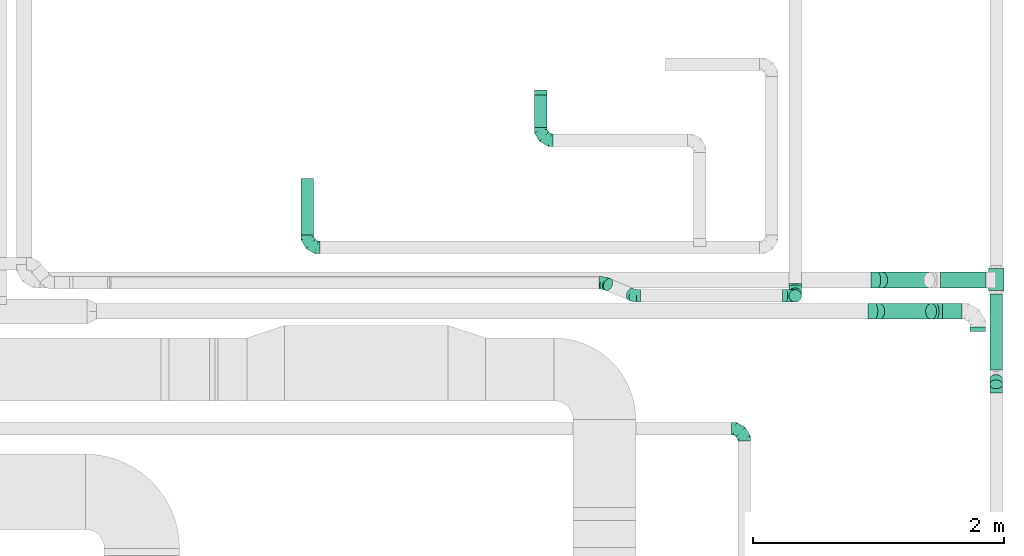
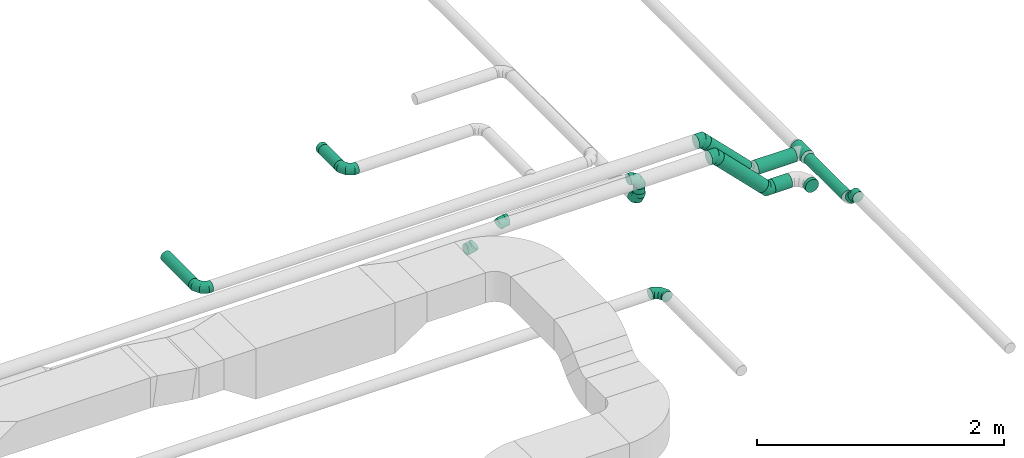
# One storey, part 50 of 60: 12 flow fittings, 11 flow segments.
"""IFC2X3 building model written with IfcOpenShell, lengths in millimetres."""

from ifc_helpers import new_model, entity, si_unit, converted_unit, derived_unit, direction, frame, origin, origin_2d_with_axis, place, context, subcontext, project, spatial, circle, extrude, faceted_brep, source, transform, mapped, material, type_object, type_shapes, element, save


model = new_model("IFC2X3")

# Units and contexts
model_context = context("Model", 3, precision=0.01, world=origin(), true_north=direction((6.12303176911189e-17, 1.0)))
body_context = subcontext(model_context, "Body", "Model", "MODEL_VIEW")
ifc_project = project(units=[si_unit("LENGTHUNIT", "METRE", prefix="MILLI"), si_unit("AREAUNIT", "SQUARE_METRE"), si_unit("VOLUMEUNIT", "CUBIC_METRE"), converted_unit("PLANEANGLEUNIT", "DEGREE", entity("IfcRatioMeasure", 0.0174532925199433), si_unit("PLANEANGLEUNIT", "RADIAN"), dimensions=[0, 0, 0, 0, 0, 0, 0]), si_unit("MASSUNIT", "GRAM", prefix="KILO"), derived_unit("MASSDENSITYUNIT", [(si_unit("MASSUNIT", "GRAM", prefix="KILO"), 1), (si_unit("LENGTHUNIT", "METRE"), -3)]), derived_unit("MOMENTOFINERTIAUNIT", [(si_unit("LENGTHUNIT", "METRE"), 4)]), si_unit("TIMEUNIT", "SECOND"), si_unit("FREQUENCYUNIT", "HERTZ"), si_unit("THERMODYNAMICTEMPERATUREUNIT", "DEGREE_CELSIUS"), derived_unit("THERMALTRANSMITTANCEUNIT", [(si_unit("MASSUNIT", "GRAM", prefix="KILO"), 1), (si_unit("THERMODYNAMICTEMPERATUREUNIT", "KELVIN"), -1), (si_unit("TIMEUNIT", "SECOND"), -3)]), derived_unit("VOLUMETRICFLOWRATEUNIT", [(si_unit("LENGTHUNIT", "METRE"), 3), (si_unit("TIMEUNIT", "SECOND"), -1)]), derived_unit("MASSFLOWRATEUNIT", [(si_unit("MASSUNIT", "GRAM", prefix="KILO"), 1), (si_unit("TIMEUNIT", "SECOND"), -1)]), derived_unit("ROTATIONALFREQUENCYUNIT", [(si_unit("TIMEUNIT", "SECOND"), -1)]), si_unit("ELECTRICCURRENTUNIT", "AMPERE"), si_unit("ELECTRICVOLTAGEUNIT", "VOLT"), si_unit("POWERUNIT", "WATT"), si_unit("FORCEUNIT", "NEWTON", prefix="KILO"), si_unit("ILLUMINANCEUNIT", "LUX"), si_unit("LUMINOUSFLUXUNIT", "LUMEN"), si_unit("LUMINOUSINTENSITYUNIT", "CANDELA"), derived_unit("USERDEFINED", [(si_unit("MASSUNIT", "GRAM", prefix="KILO"), -1), (si_unit("LENGTHUNIT", "METRE"), -2), (si_unit("TIMEUNIT", "SECOND"), 3), (si_unit("LUMINOUSFLUXUNIT", "LUMEN"), 1)]), derived_unit("LINEARVELOCITYUNIT", [(si_unit("LENGTHUNIT", "METRE"), 1), (si_unit("TIMEUNIT", "SECOND"), -1)]), si_unit("PRESSUREUNIT", "PASCAL"), derived_unit("USERDEFINED", [(si_unit("LENGTHUNIT", "METRE"), -2), (si_unit("MASSUNIT", "GRAM", prefix="KILO"), 1), (si_unit("TIMEUNIT", "SECOND"), -2)]), derived_unit("LINEARFORCEUNIT", [(si_unit("MASSUNIT", "GRAM", prefix="KILO"), 1), (si_unit("LENGTHUNIT", "METRE"), 1), (si_unit("TIMEUNIT", "SECOND"), -2), (si_unit("LENGTHUNIT", "METRE"), -1)]), derived_unit("PLANARFORCEUNIT", [(si_unit("MASSUNIT", "GRAM", prefix="KILO"), 1), (si_unit("LENGTHUNIT", "METRE"), 1), (si_unit("TIMEUNIT", "SECOND"), -2), (si_unit("LENGTHUNIT", "METRE"), -2)])], contexts=[model_context])

# Site, building, storey
site_placement = place(None, origin())
site = spatial("IfcSite", under=ifc_project, at=site_placement, CompositionType="ELEMENT")
building_placement = place(site_placement, origin())
building = spatial("IfcBuilding", under=site, at=building_placement, CompositionType="ELEMENT")
storey_placement = place(building_placement, frame((0.0, 0.0, 19800.0)))
storey = spatial("IfcBuildingStorey", under=building, at=storey_placement, CompositionType="ELEMENT", Elevation=19800.0)

# Flow segments
duct_segment_type = type_object("IfcDuctSegmentType", PredefinedType="NOTDEFINED")
flow_segment_1_placement = place(storey_placement, frame((71263.72, 9761.89, 3053.33)))
element("IfcFlowSegment", 1, at=flow_segment_1_placement, inside=storey, type_object=duct_segment_type, context=body_context, shape_type="SweptSolid", body=[
    extrude(circle(Radius=62.5, at=origin_2d_with_axis()), frame((460.07, 64.1, 45.79), z_axis=(-0.707106781186541, 0.0, 0.707106781186554), x_axis=(0.0, -1.0, 0.0)), (0.0, 0.0, 1.0), 585.875721063605),
])
flow_segment_2_placement = place(storey_placement, frame((71812.17, 9761.89, 2998.41)))
element("IfcFlowSegment", 2, at=flow_segment_2_placement, inside=storey, type_object=duct_segment_type, context=body_context, shape_type="SweptSolid", body=[
    extrude(circle(Radius=62.5, at=origin_2d_with_axis()), frame((0.01, 64.1, 64.1), z_axis=(0.999999995760712, 9.20791868074516e-05, 0.0), x_axis=(9.20791868074516e-05, -0.999999995760712, 0.0)), (0.0, 0.0, 1.0), 158.198285652603),
])
flow_segment_3_placement = place(storey_placement, frame((72031.28, 9666.3, 2998.4)))
element("IfcFlowSegment", 3, at=flow_segment_3_placement, inside=storey, type_object=duct_segment_type, context=body_context, shape_type="SweptSolid", body=[
    extrude(circle(Radius=62.5, at=origin_2d_with_axis()), frame((64.1, 0.01, 64.1), z_axis=(0.0, 0.999999993693271, 0.00011230965719456), x_axis=(-1.0, 0.0, 0.0)), (0.0, 0.0, 1.0), 34.6940980596113),
])
flow_segment_4_placement = place(storey_placement, frame((71286.91, 10011.33, 3090.85)))
element("IfcFlowSegment", 4, at=flow_segment_4_placement, inside=storey, type_object=duct_segment_type, context=body_context, shape_type="SweptSolid", body=[
    extrude(circle(Radius=62.5, at=origin_2d_with_axis()), frame((45.79, 64.1, 422.54), z_axis=(0.707106781186548, 0.0, -0.707106781186548), x_axis=(0.0, -1.0, 0.0)), (0.0, 0.0, 1.0), 532.806999099958),
])
flow_segment_5_placement = place(storey_placement, frame((71797.83, 10011.33, 3035.93)))
element("IfcFlowSegment", 5, at=flow_segment_5_placement, inside=storey, type_object=duct_segment_type, context=body_context, shape_type="SweptSolid", body=[
    extrude(circle(Radius=62.5, at=origin_2d_with_axis()), frame((0.01, 64.1, 64.1), z_axis=(0.999999996738574, 8.07641773404161e-05, 0.0), x_axis=(8.07641773404161e-05, -0.999999996738574, 0.0)), (0.0, 0.0, 1.0), 360.72352810149),
])
flow_segment_6_placement = place(storey_placement, frame((72176.96, 9990.72, 3035.81)))
element("IfcFlowSegment", 6, at=flow_segment_6_placement, inside=storey, type_object=duct_segment_type, context=body_context, shape_type="SweptSolid", body=[
    extrude(circle(Radius=62.5, at=origin_2d_with_axis()), frame((64.1, 175.01, 64.1), z_axis=(0.0, -0.999999990158603, 0.000140295384194005), x_axis=(1.0, 0.0, 0.0)), (0.0, 0.0, 1.0), 175.000000003778),
])
flow_segment_7_placement = place(storey_placement, frame((66705.01, 10434.99, 3448.4)))
element("IfcFlowSegment", 7, at=flow_segment_7_placement, inside=storey, type_object=duct_segment_type, context=body_context, shape_type="SweptSolid", body=[
    extrude(circle(Radius=50.0, at=origin_2d_with_axis()), frame((51.6, 0.0, 51.6), z_axis=(0.0, 1.0, 0.0), x_axis=(1.0, 0.0, 0.0)), (0.0, 0.0, 1.0), 450.000000000006),
])
flow_segment_8_placement = place(storey_placement, frame((68562.03, 11289.99, 3448.4)))
element("IfcFlowSegment", 8, at=flow_segment_8_placement, inside=storey, type_object=duct_segment_type, context=body_context, shape_type="SweptSolid", body=[
    extrude(circle(Radius=50.0, at=origin_2d_with_axis()), frame((51.6, 0.0, 51.6), z_axis=(0.0, 1.0, 0.0), x_axis=(1.0, 0.0, 0.0)), (0.0, 0.0, 1.0), 257.585253206116),
])
flow_segment_9_placement = place(storey_placement, frame((72189.46, 9208.07, 3092.34)))
element("IfcFlowSegment", 9, at=flow_segment_9_placement, inside=storey, type_object=duct_segment_type, context=body_context, shape_type="SweptSolid", body=[
    extrude(circle(Radius=50.0, at=origin_2d_with_axis()), frame((51.6, 36.95, 78.37), z_axis=(0.0, 0.707106781186548, -0.707106781186548), x_axis=(1.0, 0.0, 0.0)), (0.0, 0.0, 1.0), 58.5711812334434),
])
flow_segment_10_placement = place(storey_placement, frame((72189.46, 9357.14, 3048.31)))
element("IfcFlowSegment", 10, at=flow_segment_10_placement, inside=storey, type_object=duct_segment_type, context=body_context, shape_type="SweptSolid", body=[
    extrude(circle(Radius=50.0, at=origin_2d_with_axis()), frame((51.6, 0.01, 51.69), z_axis=(0.0, 0.999999986658688, -0.00016334816538309), x_axis=(1.0, 0.0, 0.0)), (0.0, 0.0, 1.0), 608.583325078976),
])
flow_segment_11_placement = place(storey_placement, frame((70589.2, 9897.61, 3350.0)))
element("IfcFlowSegment", 11, at=flow_segment_11_placement, inside=storey, type_object=duct_segment_type, context=body_context, shape_type="SweptSolid", body=[
    extrude(circle(Radius=50.0, at=origin_2d_with_axis()), frame((51.6, 51.6, 0.0), z_axis=(0.0, 0.0, 1.0), x_axis=(0.0, 1.0, 0.0)), (0.0, 0.0, 1.0), 50.0000000000233),
])

# Flow fittings
ifc_material = material()
duct_fitting_type_1 = type_object("IfcDuctFittingType", PredefinedType="NOTDEFINED", material=ifc_material)
shared_shape_1 = source(origin(), body_context, "Body", "Brep", [
    faceted_brep([(-100.0, 0.0, -50.0), (-100.0, -12.94, -48.3), (-100.0, -25.0, -43.3), (-100.0, -35.36, -35.36), (-100.0, -43.3, -25.0), (-100.0, -48.3, -12.94), (-100.0, -50.0, 0.0), (-100.0, -48.3, 12.94), (-100.0, -43.3, 25.0), (-100.0, -35.36, 35.36), (-100.0, -25.0, 43.3), (-100.0, -12.94, 48.3), (-100.0, 0.0, 50.0), (-100.0, 12.94, 48.3), (-100.0, 25.0, 43.3), (-100.0, 35.36, 35.36), (-100.0, 43.3, 25.0), (-100.0, 48.3, 12.94), (-100.0, 50.0, 0.0), (-100.0, 48.3, -12.94), (-100.0, 43.3, -25.0), (-100.0, 35.36, -35.36), (-100.0, 25.0, -43.3), (-100.0, 12.94, -48.3), (-76.67, 12.94, 48.3), (-79.9, 25.0, 43.3), (-73.21, 0.0, 50.0), (-82.68, 35.36, 35.36), (-86.15, 48.3, 12.94), (-86.6, 50.0, 0.0), (-84.81, 43.3, 25.0), (-84.81, 43.3, -25.0), (-82.68, 35.36, -35.36), (-86.15, 48.3, -12.94), (-76.67, 12.94, -48.3), (-73.21, 0.0, -50.0), (-79.9, 25.0, -43.3), (-69.74, -12.94, -48.3), (-66.51, -25.0, -43.3), (-63.73, -35.36, -35.36), (-61.6, -43.3, -25.0), (-60.26, -48.3, -12.94), (-59.81, -50.0, 0.0), (-60.26, -48.3, 12.94), (-61.6, -43.3, 25.0), (-63.73, -35.36, 35.36), (-66.51, -25.0, 43.3), (-69.74, -12.94, 48.3), (-36.27, 36.27, 48.3), (-45.1, 45.1, 43.3), (-26.79, 26.79, 50.0), (-52.68, 52.68, 35.36), (-58.49, 58.49, 25.0), (-62.15, 62.15, 12.94), (-63.4, 63.4, 0.0), (-62.15, 62.15, -12.94), (-58.49, 58.49, -25.0), (-52.68, 52.68, -35.36), (-36.27, 36.27, -48.3), (-26.79, 26.79, -50.0), (-45.1, 45.1, -43.3), (-17.32, 17.32, -48.3), (-8.49, 8.49, -43.3), (-0.91, 0.91, -35.36), (4.9, -4.9, -25.0), (8.56, -8.56, -12.94), (9.81, -9.81, 0.0), (8.56, -8.56, 12.94), (4.9, -4.9, 25.0), (-0.91, 0.91, 35.36), (-8.49, 8.49, 43.3), (-17.32, 17.32, 48.3), (-12.94, 76.67, 48.3), (-25.0, 79.9, 43.3), (0.0, 73.21, 50.0), (-35.36, 82.68, 35.36), (-43.3, 84.81, 25.0), (-48.3, 86.15, 12.94), (-50.0, 86.6, 0.0), (-48.3, 86.15, -12.94), (-43.3, 84.81, -25.0), (-35.36, 82.68, -35.36), (-12.94, 76.67, -48.3), (0.0, 73.21, -50.0), (-25.0, 79.9, -43.3), (12.94, 69.74, -48.3), (25.0, 66.51, -43.3), (35.36, 63.73, -35.36), (43.3, 61.6, -25.0), (48.3, 60.26, -12.94), (50.0, 59.81, 0.0), (48.3, 60.26, 12.94), (43.3, 61.6, 25.0), (35.36, 63.73, 35.36), (25.0, 66.51, 43.3), (12.94, 69.74, 48.3), (-12.94, 100.0, -48.3), (-25.0, 100.0, -43.3), (-35.36, 100.0, -35.36), (-43.3, 100.0, -25.0), (-48.3, 100.0, -12.94), (-50.0, 100.0, 0.0), (-48.3, 100.0, 12.94), (-43.3, 100.0, 25.0), (-35.36, 100.0, 35.36), (-25.0, 100.0, 43.3), (-12.94, 100.0, 48.3), (0.0, 100.0, 50.0), (12.94, 100.0, 48.3), (25.0, 100.0, 43.3), (35.36, 100.0, 35.36), (43.3, 100.0, 25.0), (48.3, 100.0, 12.94), (50.0, 100.0, 0.0), (48.3, 100.0, -12.94), (43.3, 100.0, -25.0), (35.36, 100.0, -35.36), (25.0, 100.0, -43.3), (12.94, 100.0, -48.3), (0.0, 100.0, -50.0)], [[[0, 1, 2, 3, 4, 5, 6, 7, 8, 9, 10, 11, 12, 13, 14, 15, 16, 17, 18, 19, 20, 21, 22, 23]], [[24, 25, 14, 13]], [[26, 24, 13, 12]], [[14, 25, 27, 15]], [[28, 29, 18, 17]], [[30, 28, 17, 16]], [[15, 27, 30, 16]], [[20, 31, 32, 21]], [[33, 31, 20, 19]], [[18, 29, 33, 19]], [[34, 35, 0, 23]], [[36, 34, 23, 22]], [[32, 36, 22, 21]], [[2, 1, 37, 38]], [[3, 2, 38, 39]], [[0, 35, 37, 1]], [[5, 4, 40, 41]], [[6, 5, 41, 42]], [[3, 39, 40, 4]], [[6, 42, 43, 7]], [[7, 43, 44, 8]], [[8, 44, 45, 9]], [[10, 46, 47, 11]], [[11, 47, 26, 12]], [[10, 9, 45, 46]], [[48, 49, 25, 24]], [[50, 48, 24, 26]], [[27, 25, 49, 51]], [[52, 53, 28, 30]], [[51, 52, 30, 27]], [[29, 28, 53, 54]], [[55, 56, 31, 33]], [[54, 55, 33, 29]], [[57, 32, 31, 56]], [[58, 59, 35, 34]], [[60, 58, 34, 36]], [[57, 60, 36, 32]], [[37, 35, 59, 61]], [[38, 37, 61, 62]], [[39, 38, 62, 63]], [[41, 40, 64, 65]], [[42, 41, 65, 66]], [[63, 64, 40, 39]], [[43, 42, 66, 67]], [[44, 43, 67, 68]], [[68, 69, 45, 44]], [[46, 45, 69, 70]], [[47, 46, 70, 71]], [[26, 47, 71, 50]], [[72, 73, 49, 48]], [[74, 72, 48, 50]], [[51, 49, 73, 75]], [[76, 77, 53, 52]], [[75, 76, 52, 51]], [[54, 53, 77, 78]], [[79, 80, 56, 55]], [[78, 79, 55, 54]], [[81, 57, 56, 80]], [[82, 83, 59, 58]], [[84, 82, 58, 60]], [[81, 84, 60, 57]], [[61, 59, 83, 85]], [[62, 61, 85, 86]], [[63, 62, 86, 87]], [[65, 64, 88, 89]], [[66, 65, 89, 90]], [[87, 88, 64, 63]], [[67, 66, 90, 91]], [[68, 67, 91, 92]], [[92, 93, 69, 68]], [[70, 69, 93, 94]], [[71, 70, 94, 95]], [[50, 71, 95, 74]], [[96, 97, 98, 99, 100, 101, 102, 103, 104, 105, 106, 107, 108, 109, 110, 111, 112, 113, 114, 115, 116, 117, 118, 119]], [[72, 74, 107, 106]], [[73, 72, 106, 105]], [[75, 73, 105, 104]], [[77, 76, 103, 102]], [[78, 77, 102, 101]], [[75, 104, 103, 76]], [[78, 101, 100, 79]], [[79, 100, 99, 80]], [[80, 99, 98, 81]], [[96, 119, 83, 82]], [[97, 96, 82, 84]], [[84, 81, 98, 97]], [[83, 119, 118, 85]], [[85, 118, 117, 86]], [[86, 117, 116, 87]], [[88, 115, 114, 89]], [[89, 114, 113, 90]], [[87, 116, 115, 88]], [[91, 90, 113, 112]], [[92, 91, 112, 111]], [[93, 92, 111, 110]], [[95, 94, 109, 108]], [[74, 95, 108, 107]], [[110, 109, 94, 93]]]),
])
type_shapes(duct_fitting_type_1, [shared_shape_1])
for number, where, z_axis, x_axis in (
    (12, (70234.19, 8891.89, 3150.0), (0.0, 0.0, 1.0), (0.0, 1.0, 0.0)),
    (13, (66756.61, 10334.99, 3500.0), (0.0, 0.0, 1.0), (0.0, -1.0, 0.0)),
    (14, (68613.63, 11189.99, 3500.0), (0.0, 0.0, 1.0), (0.0, -1.0, 0.0)),
    (15, (70640.8, 9949.2, 3250.0), (-1.0, 0.0, 0.0), (0.0, -1.0, 0.0)),
    (16, (70640.8, 9949.2, 3500.0), (0.0, -1.0, 0.0), (0.0, 0.0, 1.0)),
):
    element("IfcFlowFitting", number, at=place(storey_placement, frame(where, z_axis=z_axis, x_axis=x_axis)), inside=storey, type_object=duct_fitting_type_1, material=ifc_material, context=body_context, shape_type="MappedRepresentation", body=[
        mapped(shared_shape_1, transform((0.0, 0.0, 0.0), scale=1.0)),
    ])
duct_fitting_type_2 = type_object("IfcDuctFittingType", PredefinedType="NOTDEFINED", material=ifc_material)
shared_shape_2 = source(origin(), body_context, "Body", "Brep", [
    faceted_brep([(-51.78, 0.0, -62.5), (-51.78, -16.18, -60.37), (-51.78, -31.25, -54.13), (-51.78, -44.19, -44.19), (-51.78, -54.13, -31.25), (-51.78, -60.37, -16.18), (-51.78, -62.5, 0.0), (-51.78, -60.37, 16.18), (-51.78, -54.13, 31.25), (-51.78, -44.19, 44.19), (-51.78, -31.25, 54.13), (-51.78, -16.18, 60.37), (-51.78, 0.0, 62.5), (-51.78, 16.18, 60.37), (-51.78, 31.25, 54.13), (-51.78, 44.19, 44.19), (-51.78, 54.13, 31.25), (-51.78, 60.37, 16.18), (-51.78, 62.5, 0.0), (-51.78, 60.37, -16.18), (-51.78, 54.13, -31.25), (-51.78, 44.19, -44.19), (-51.78, 31.25, -54.13), (-51.78, 16.18, -60.37), (-6.7, 16.18, 60.37), (-12.94, 31.25, 54.13), (0.0, 0.0, 62.5), (-18.31, 44.19, 44.19), (-22.42, 54.13, 31.25), (-25.01, 60.37, 16.18), (-25.89, 62.5, 0.0), (-25.01, 60.37, -16.18), (-22.42, 54.13, -31.25), (-18.31, 44.19, -44.19), (-6.7, 16.18, -60.37), (0.0, 0.0, -62.5), (-12.94, 31.25, -54.13), (6.7, -16.18, -60.37), (12.94, -31.25, -54.13), (18.31, -44.19, -44.19), (22.42, -54.13, -31.25), (25.01, -60.37, -16.18), (25.89, -62.5, 0.0), (25.01, -60.37, 16.18), (22.42, -54.13, 31.25), (18.31, -44.19, 44.19), (12.94, -31.25, 54.13), (6.7, -16.18, 60.37), (25.17, 48.05, 60.37), (14.51, 58.71, 54.13), (36.61, 36.61, 62.5), (5.36, 67.86, 44.19), (-1.66, 74.88, 31.25), (-6.08, 79.3, 16.18), (-7.58, 80.81, 0.0), (-6.08, 79.3, -16.18), (-1.66, 74.88, -31.25), (5.36, 67.86, -44.19), (14.51, 58.71, -54.13), (25.17, 48.05, -60.37), (36.61, 36.61, -62.5), (48.05, 25.17, -60.37), (58.71, 14.51, -54.13), (67.86, 5.36, -44.19), (74.88, -1.66, -31.25), (79.3, -6.08, -16.18), (80.81, -7.58, 0.0), (79.3, -6.08, 16.18), (74.88, -1.66, 31.25), (67.86, 5.36, 44.19), (58.71, 14.51, 54.13), (48.05, 25.17, 60.37)], [[[0, 1, 2, 3, 4, 5, 6, 7, 8, 9, 10, 11, 12, 13, 14, 15, 16, 17, 18, 19, 20, 21, 22, 23]], [[24, 25, 14, 13]], [[26, 24, 13, 12]], [[27, 15, 14, 25]], [[28, 29, 17, 16]], [[28, 16, 15, 27]], [[30, 18, 17, 29]], [[31, 32, 20, 19]], [[30, 31, 19, 18]], [[21, 20, 32, 33]], [[34, 35, 0, 23]], [[36, 34, 23, 22]], [[33, 36, 22, 21]], [[1, 0, 35, 37]], [[2, 1, 37, 38]], [[38, 39, 3, 2]], [[5, 4, 40, 41]], [[6, 5, 41, 42]], [[39, 40, 4, 3]], [[6, 42, 43, 7]], [[7, 43, 44, 8]], [[8, 44, 45, 9]], [[9, 45, 46, 10]], [[10, 46, 47, 11]], [[26, 12, 11, 47]], [[48, 49, 25, 24]], [[50, 48, 24, 26]], [[27, 25, 49, 51]], [[29, 28, 52, 53]], [[30, 29, 53, 54]], [[51, 52, 28, 27]], [[30, 54, 55, 31]], [[31, 55, 56, 32]], [[57, 33, 32, 56]], [[36, 58, 59, 34]], [[34, 59, 60, 35]], [[58, 36, 33, 57]], [[35, 60, 61, 37]], [[37, 61, 62, 38]], [[63, 39, 38, 62]], [[40, 64, 65, 41]], [[41, 65, 66, 42]], [[64, 40, 39, 63]], [[43, 42, 66, 67]], [[44, 43, 67, 68]], [[68, 69, 45, 44]], [[47, 46, 70, 71]], [[26, 47, 71, 50]], [[69, 70, 46, 45]], [[59, 58, 57, 56, 55, 54, 53, 52, 51, 49, 48, 50, 71, 70, 69, 68, 67, 66, 65, 64, 63, 62, 61, 60]]]),
])
type_shapes(duct_fitting_type_2, [shared_shape_2])
for number, where, z_axis, x_axis in (
    (17, (71272.9, 9825.98, 3550.0), (0.0, 1.0, 0.0), (1.0, 0.0, 0.0)),
    (18, (71760.4, 9825.98, 3062.5), (0.0, -1.0, 0.0), (0.707106781186534, 0.0, -0.707106781186561)),
    (19, (71296.09, 10075.43, 3550.0), (0.0, 1.0, 0.0), (1.0, 0.0, 0.0)),
):
    element("IfcFlowFitting", number, at=place(storey_placement, frame(where, z_axis=z_axis, x_axis=x_axis)), inside=storey, type_object=duct_fitting_type_2, material=ifc_material, context=body_context, shape_type="MappedRepresentation", body=[
        mapped(shared_shape_2, transform((0.0, 0.0, 0.0), scale=1.0)),
    ])
duct_fitting_type_3 = type_object("IfcDuctFittingType", PredefinedType="NOTDEFINED", material=ifc_material)
shared_shape_3 = source(origin(), body_context, "Body", "Brep", [
    faceted_brep([(-41.42, 0.0, -50.0), (-41.42, -12.94, -48.3), (-41.42, -25.0, -43.3), (-41.42, -35.36, -35.36), (-41.42, -43.3, -25.0), (-41.42, -48.3, -12.94), (-41.42, -50.0, 0.0), (-41.42, -48.3, 12.94), (-41.42, -43.3, 25.0), (-41.42, -35.36, 35.36), (-41.42, -25.0, 43.3), (-41.42, -12.94, 48.3), (-41.42, 0.0, 50.0), (-41.42, 12.94, 48.3), (-41.42, 25.0, 43.3), (-41.42, 35.36, 35.36), (-41.42, 43.3, 25.0), (-41.42, 48.3, 12.94), (-41.42, 50.0, 0.0), (-41.42, 48.3, -12.94), (-41.42, 43.3, -25.0), (-41.42, 35.36, -35.36), (-41.42, 25.0, -43.3), (-41.42, 12.94, -48.3), (-5.36, 12.94, 48.3), (-10.36, 25.0, 43.3), (0.0, 0.0, 50.0), (-14.64, 35.36, 35.36), (-20.0, 48.3, 12.94), (-20.71, 50.0, 0.0), (-17.94, 43.3, 25.0), (-17.94, 43.3, -25.0), (-14.64, 35.36, -35.36), (-20.0, 48.3, -12.94), (-5.36, 12.94, -48.3), (0.0, 0.0, -50.0), (-10.36, 25.0, -43.3), (5.36, -12.94, -48.3), (10.36, -25.0, -43.3), (14.64, -35.36, -35.36), (17.94, -43.3, -25.0), (20.0, -48.3, -12.94), (20.71, -50.0, 0.0), (20.0, -48.3, 12.94), (17.94, -43.3, 25.0), (14.64, -35.36, 35.36), (10.36, -25.0, 43.3), (5.36, -12.94, 48.3), (29.29, 29.29, 50.0), (20.14, 38.44, 48.3), (11.61, 46.97, 43.3), (4.29, 54.29, 35.36), (-1.33, 59.91, 25.0), (-4.86, 63.44, 12.94), (-6.07, 64.64, 0.0), (-4.86, 63.44, -12.94), (-1.33, 59.91, -25.0), (4.29, 54.29, -35.36), (11.61, 46.97, -43.3), (20.14, 38.44, -48.3), (29.29, 29.29, -50.0), (38.44, 20.14, -48.3), (46.97, 11.61, -43.3), (54.29, 4.29, -35.36), (59.91, -1.33, -25.0), (63.44, -4.86, -12.94), (64.64, -6.07, 0.0), (63.44, -4.86, 12.94), (59.91, -1.33, 25.0), (54.29, 4.29, 35.36), (46.97, 11.61, 43.3), (38.44, 20.14, 48.3)], [[[0, 1, 2, 3, 4, 5, 6, 7, 8, 9, 10, 11, 12, 13, 14, 15, 16, 17, 18, 19, 20, 21, 22, 23]], [[24, 25, 14, 13]], [[26, 24, 13, 12]], [[14, 25, 27, 15]], [[28, 29, 18, 17]], [[30, 28, 17, 16]], [[16, 15, 27, 30]], [[20, 31, 32, 21]], [[33, 31, 20, 19]], [[18, 29, 33, 19]], [[34, 35, 0, 23]], [[36, 34, 23, 22]], [[32, 36, 22, 21]], [[1, 0, 35, 37]], [[2, 1, 37, 38]], [[38, 39, 3, 2]], [[5, 4, 40, 41]], [[6, 5, 41, 42]], [[39, 40, 4, 3]], [[6, 42, 43, 7]], [[7, 43, 44, 8]], [[8, 44, 45, 9]], [[9, 45, 46, 10]], [[10, 46, 47, 11]], [[26, 12, 11, 47]], [[24, 26, 48, 49]], [[25, 24, 49, 50]], [[27, 25, 50, 51]], [[28, 30, 52, 53]], [[29, 28, 53, 54]], [[27, 51, 52, 30]], [[29, 54, 55, 33]], [[33, 55, 56, 31]], [[31, 56, 57, 32]], [[36, 58, 59, 34]], [[34, 59, 60, 35]], [[36, 32, 57, 58]], [[61, 62, 38, 37]], [[60, 61, 37, 35]], [[63, 39, 38, 62]], [[40, 64, 65, 41]], [[41, 65, 66, 42]], [[64, 40, 39, 63]], [[43, 42, 66, 67]], [[44, 43, 67, 68]], [[68, 69, 45, 44]], [[47, 46, 70, 71]], [[26, 47, 71, 48]], [[69, 70, 46, 45]], [[59, 58, 57, 56, 55, 54, 53, 52, 51, 50, 49, 48, 71, 70, 69, 68, 67, 66, 65, 64, 63, 62, 61, 60]]]),
])
type_shapes(duct_fitting_type_3, [shared_shape_3])
flow_fitting_1_placement = place(storey_placement, frame((72241.06, 9215.73, 3200.0), z_axis=(-1.0, 0.0, 0.0), x_axis=(0.0, 1.0, 0.0)))
element("IfcFlowFitting", 20, at=flow_fitting_1_placement, inside=storey, type_object=duct_fitting_type_3, material=ifc_material, context=body_context, shape_type="MappedRepresentation", body=[
    mapped(shared_shape_3, transform((0.0, 0.0, 0.0), scale=1.0)),
])
duct_fitting_type_4 = type_object("IfcDuctFittingType", PredefinedType="NOTDEFINED", material=ifc_material)
shared_shape_4 = source(origin(), body_context, "Body", "Brep", [
    faceted_brep([(20.0, 12.94, -48.3), (20.0, 25.0, -43.3), (20.0, 35.36, -35.36), (20.0, 43.3, -25.0), (20.0, 48.3, -12.94), (20.0, 50.0, 0.0), (20.0, 48.3, 12.94), (20.0, 43.3, 25.0), (20.0, 35.36, 35.36), (20.0, 25.0, 43.3), (20.0, 12.94, 48.3), (20.0, 0.0, 50.0), (20.0, -12.94, 48.3), (20.0, -25.0, 43.3), (20.0, -35.36, 35.36), (20.0, -43.3, 25.0), (20.0, -48.3, 12.94), (20.0, -50.0, 0.0), (20.0, -48.3, -12.94), (20.0, -43.3, -25.0), (20.0, -35.36, -35.36), (20.0, -25.0, -43.3), (20.0, -12.94, -48.3), (20.0, 0.0, -50.0), (0.0, 0.0, 50.0), (0.0, 12.94, 48.3), (-19.49, 12.94, 48.3), (-19.49, 0.0, 50.0), (0.0, 25.0, 43.3), (-19.49, 25.0, 43.3), (0.0, 35.36, 35.36), (-19.49, 35.36, 35.36), (0.0, 43.3, 25.0), (0.0, 48.3, 12.94), (-19.49, 48.3, 12.94), (-19.49, 43.3, 25.0), (0.0, 50.0, 0.0), (-19.49, 50.0, 0.0), (0.0, 48.3, -12.94), (-19.49, 48.3, -12.94), (0.0, 43.3, -25.0), (-19.49, 43.3, -25.0), (0.0, 35.36, -35.36), (-19.49, 35.36, -35.36), (0.0, 25.0, -43.3), (0.0, 12.94, -48.3), (-19.49, 12.94, -48.3), (-19.49, 25.0, -43.3), (0.0, 0.0, -50.0), (-19.49, 0.0, -50.0), (0.0, -12.94, -48.3), (-19.49, -12.94, -48.3), (0.0, -25.0, -43.3), (-19.49, -25.0, -43.3), (0.0, -35.36, -35.36), (-19.49, -35.36, -35.36), (0.0, -43.3, -25.0), (0.0, -48.3, -12.94), (-19.49, -48.3, -12.94), (-19.49, -43.3, -25.0), (0.0, -50.0, 0.0), (-19.49, -50.0, 0.0), (0.0, -48.3, 12.94), (-19.49, -48.3, 12.94), (0.0, -43.3, 25.0), (-19.49, -43.3, 25.0), (0.0, -35.36, 35.36), (-19.49, -35.36, 35.36), (0.0, -25.0, 43.3), (0.0, -12.94, 48.3), (-19.49, -12.94, 48.3), (-19.49, -25.0, 43.3)], [[[0, 1, 2, 3, 4, 5, 6, 7, 8, 9, 10, 11, 12, 13, 14, 15, 16, 17, 18, 19, 20, 21, 22, 23]], [[24, 11, 10, 25, 26, 27]], [[25, 10, 9, 28, 29, 26]], [[28, 9, 8, 30, 31, 29]], [[32, 7, 6, 33, 34, 35]], [[33, 6, 5, 36, 37, 34]], [[30, 8, 7, 32, 35, 31]], [[36, 5, 4, 38, 39, 37]], [[38, 4, 3, 40, 41, 39]], [[40, 3, 2, 42, 43, 41]], [[44, 1, 0, 45, 46, 47]], [[45, 0, 23, 48, 49, 46]], [[42, 2, 1, 44, 47, 43]], [[48, 23, 22, 50, 51, 49]], [[50, 22, 21, 52, 53, 51]], [[52, 21, 20, 54, 55, 53]], [[56, 19, 18, 57, 58, 59]], [[57, 18, 17, 60, 61, 58]], [[54, 20, 19, 56, 59, 55]], [[60, 17, 16, 62, 63, 61]], [[62, 16, 15, 64, 65, 63]], [[64, 15, 14, 66, 67, 65]], [[68, 13, 12, 69, 70, 71]], [[69, 12, 11, 24, 27, 70]], [[66, 14, 13, 68, 71, 67]], [[49, 51, 53, 55, 59, 58, 61, 63, 65, 67, 71, 70, 27, 26, 29, 31, 35, 34, 37, 39, 41, 43, 47, 46]]]),
])
type_shapes(duct_fitting_type_4, [shared_shape_4])
flow_fitting_2_placement = place(storey_placement, frame((68613.63, 11567.58, 3500.0), z_axis=(-1.0, 0.0, 0.0), x_axis=(0.0, -1.0, 0.0)))
element("IfcFlowFitting", 21, at=flow_fitting_2_placement, inside=storey, type_object=duct_fitting_type_4, material=ifc_material, context=body_context, shape_type="MappedRepresentation", body=[
    mapped(shared_shape_4, transform((0.0, 0.0, 0.0), scale=1.0)),
])
duct_fitting_type_5 = type_object("IfcDuctFittingType", PredefinedType="NOTDEFINED", material=ifc_material)
shared_shape_5 = source(origin(), body_context, "Body", "Brep", [
    faceted_brep([(-43.87, 0.0, -50.0), (-43.87, -12.94, -48.3), (-43.87, -25.0, -43.3), (-43.87, -35.36, -35.36), (-43.87, -43.3, -25.0), (-43.87, -48.3, -12.94), (-43.87, -50.0, 0.0), (-43.87, -48.3, 12.94), (-43.87, -43.3, 25.0), (-43.87, -35.36, 35.36), (-43.87, -25.0, 43.3), (-43.87, -12.94, 48.3), (-43.87, 0.0, 50.0), (-43.87, 12.94, 48.3), (-43.87, 25.0, 43.3), (-43.87, 35.36, 35.36), (-43.87, 43.3, 25.0), (-43.87, 48.3, 12.94), (-43.87, 50.0, 0.0), (-43.87, 48.3, -12.94), (-43.87, 43.3, -25.0), (-43.87, 35.36, -35.36), (-43.87, 25.0, -43.3), (-43.87, 12.94, -48.3), (-25.61, 12.94, 48.3), (-28.14, 25.0, 43.3), (-22.9, 0.0, 50.0), (-30.31, 35.36, 35.36), (-33.03, 48.3, 12.94), (-33.39, 50.0, 0.0), (-31.98, 43.3, 25.0), (-31.98, 43.3, -25.0), (-30.31, 35.36, -35.36), (-33.03, 48.3, -12.94), (-25.61, 12.94, -48.3), (-22.9, 0.0, -50.0), (-28.14, 25.0, -43.3), (-20.19, -12.94, -48.3), (-17.66, -25.0, -43.3), (-15.49, -35.36, -35.36), (-13.82, -43.3, -25.0), (-12.77, -48.3, -12.94), (-12.41, -50.0, 0.0), (-12.77, -48.3, 12.94), (-13.82, -43.3, 25.0), (-15.49, -35.36, 35.36), (-17.66, -25.0, 43.3), (-20.19, -12.94, 48.3), (7.82, 27.61, 48.3), (0.66, 37.64, 43.3), (15.51, 16.85, 50.0), (-5.49, 46.25, 35.36), (-13.17, 57.01, 12.94), (-14.18, 58.43, 0.0), (-10.2, 52.86, 25.0), (-10.2, 52.86, -25.0), (-5.49, 46.25, -35.36), (-13.17, 57.01, -12.94), (7.82, 27.61, -48.3), (15.51, 16.85, -50.0), (0.66, 37.64, -43.3), (23.19, 6.09, -48.3), (30.35, -3.94, -43.3), (36.5, -12.55, -35.36), (41.22, -19.15, -25.0), (44.19, -23.31, -12.94), (45.2, -24.72, 0.0), (44.19, -23.31, 12.94), (41.22, -19.15, 25.0), (36.5, -12.55, 35.36), (30.35, -3.94, 43.3), (23.19, 6.09, 48.3), (29.71, 32.28, 50.0), (20.19, 41.04, 48.3), (11.31, 49.21, 43.3), (3.69, 56.22, 35.36), (-2.15, 61.6, 25.0), (-5.83, 64.99, 12.94), (-7.08, 66.14, 0.0), (-5.83, 64.99, -12.94), (-2.15, 61.6, -25.0), (3.69, 56.22, -35.36), (11.31, 49.21, -43.3), (20.19, 41.04, -48.3), (29.71, 32.28, -50.0), (39.23, 23.52, -48.3), (48.1, 15.35, -43.3), (55.72, 8.34, -35.36), (61.57, 2.96, -25.0), (65.25, -0.42, -12.94), (66.5, -1.58, 0.0), (65.25, -0.42, 12.94), (61.57, 2.96, 25.0), (55.72, 8.34, 35.36), (48.1, 15.35, 43.3), (39.23, 23.52, 48.3)], [[[0, 1, 2, 3, 4, 5, 6, 7, 8, 9, 10, 11, 12, 13, 14, 15, 16, 17, 18, 19, 20, 21, 22, 23]], [[24, 25, 14, 13]], [[26, 24, 13, 12]], [[14, 25, 27, 15]], [[28, 29, 18, 17]], [[30, 28, 17, 16]], [[15, 27, 30, 16]], [[20, 31, 32, 21]], [[33, 31, 20, 19]], [[18, 29, 33, 19]], [[34, 35, 0, 23]], [[36, 34, 23, 22]], [[32, 36, 22, 21]], [[2, 1, 37, 38]], [[3, 2, 38, 39]], [[0, 35, 37, 1]], [[5, 4, 40, 41]], [[6, 5, 41, 42]], [[39, 40, 4, 3]], [[6, 42, 43, 7]], [[7, 43, 44, 8]], [[8, 44, 45, 9]], [[10, 46, 47, 11]], [[11, 47, 26, 12]], [[9, 45, 46, 10]], [[48, 49, 25, 24]], [[50, 48, 24, 26]], [[25, 49, 51, 27]], [[52, 53, 29, 28]], [[54, 52, 28, 30]], [[27, 51, 54, 30]], [[55, 56, 32, 31]], [[57, 55, 31, 33]], [[53, 57, 33, 29]], [[58, 59, 35, 34]], [[60, 58, 34, 36]], [[36, 32, 56, 60]], [[35, 59, 61, 37]], [[38, 37, 61, 62]], [[39, 38, 62, 63]], [[41, 40, 64, 65]], [[42, 41, 65, 66]], [[63, 64, 40, 39]], [[43, 42, 66, 67]], [[44, 43, 67, 68]], [[68, 69, 45, 44]], [[46, 45, 69, 70]], [[47, 46, 70, 71]], [[26, 47, 71, 50]], [[48, 50, 72, 73]], [[49, 48, 73, 74]], [[51, 49, 74, 75]], [[52, 54, 76, 77]], [[53, 52, 77, 78]], [[51, 75, 76, 54]], [[53, 78, 79, 57]], [[57, 79, 80, 55]], [[55, 80, 81, 56]], [[60, 82, 83, 58]], [[58, 83, 84, 59]], [[60, 56, 81, 82]], [[59, 84, 85, 61]], [[61, 85, 86, 62]], [[62, 86, 87, 63]], [[64, 88, 89, 65]], [[65, 89, 90, 66]], [[63, 87, 88, 64]], [[67, 66, 90, 91]], [[68, 67, 91, 92]], [[69, 68, 92, 93]], [[71, 70, 94, 95]], [[50, 71, 95, 72]], [[93, 94, 70, 69]], [[83, 82, 81, 80, 79, 78, 77, 76, 75, 74, 73, 72, 95, 94, 93, 92, 91, 90, 89, 88, 87, 86, 85, 84]]]),
])
type_shapes(duct_fitting_type_5, [shared_shape_5])
for number, where, z_axis, x_axis in (
    (22, (69120.8, 10052.2, 3257.65), (0.0, -0.920330918458451, -0.391140640344906), (1.0, 0.0, 0.0)),
    (23, (69363.15, 9949.2, 3500.0), (0.0, 0.92033091845845, 0.391140640344909), (0.677188394410884, -0.287805067624669, 0.677188394410868)),
):
    element("IfcFlowFitting", number, at=place(storey_placement, frame(where, z_axis=z_axis, x_axis=x_axis)), inside=storey, type_object=duct_fitting_type_5, material=ifc_material, context=body_context, shape_type="MappedRepresentation", body=[
        mapped(shared_shape_5, transform((0.0, 0.0, 0.0), scale=1.0)),
    ])

save(model, "model.ifc")
